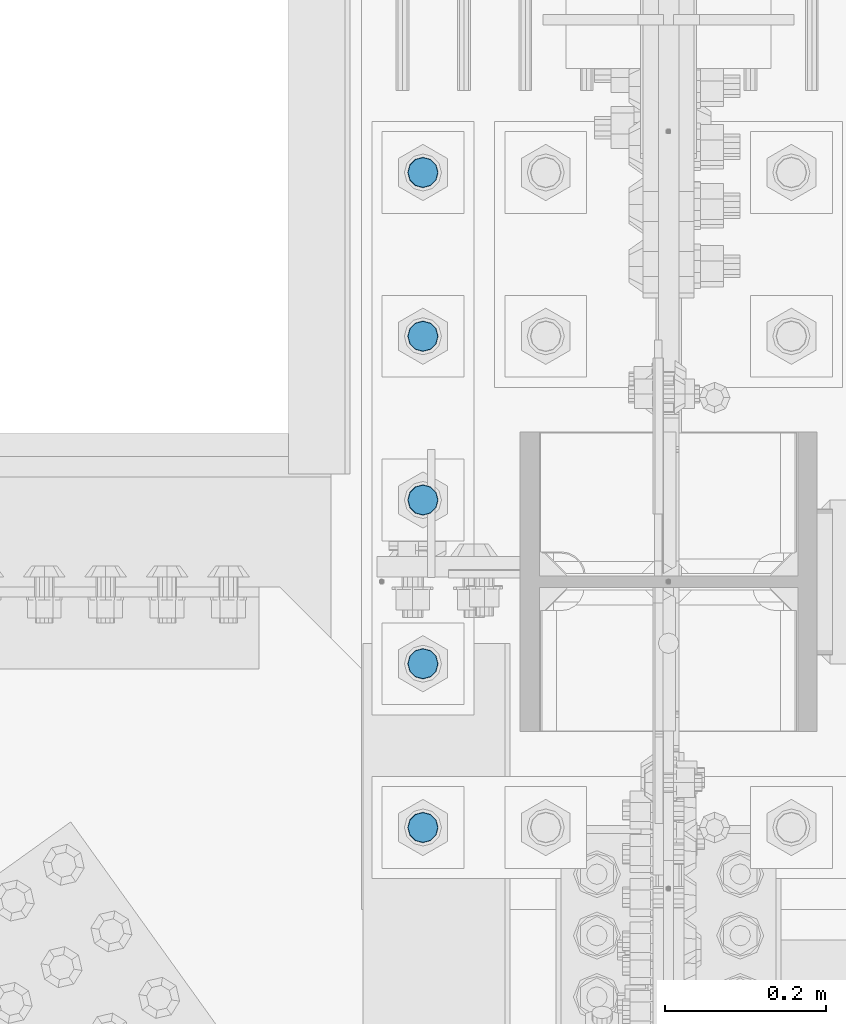
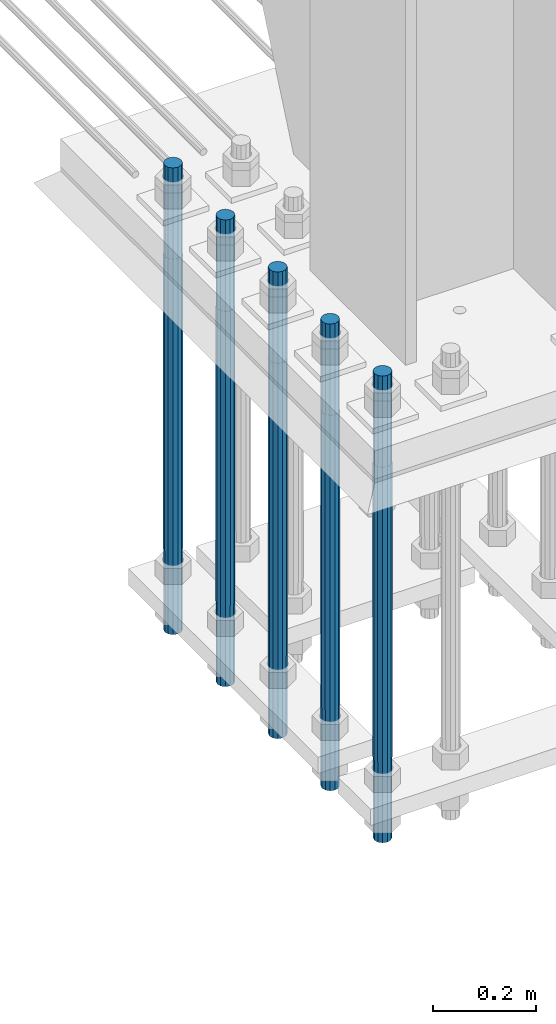
# One storey, part 1422 of 3843: 5 columns, 1 element without a shape of its own.
"""IFC2X3 building model written with IfcOpenShell, lengths in millimetres."""

from ifc_helpers import new_model, si_unit, frame, origin_with_axes, place, context, subcontext, project, spatial, faceted_brep, material, type_object, element, aggregate, save


model = new_model("IFC2X3")

# Units and contexts
model_context = context("Model", 3, precision=1e-05, world=origin_with_axes())
body_context = subcontext(model_context, "Body", "Model", "MODEL_VIEW")
ifc_project = project(units=[si_unit("LENGTHUNIT", "METRE", prefix="MILLI"), si_unit("AREAUNIT", "SQUARE_METRE"), si_unit("VOLUMEUNIT", "CUBIC_METRE"), si_unit("MASSUNIT", "GRAM", prefix="KILO"), si_unit("TIMEUNIT", "SECOND"), si_unit("PLANEANGLEUNIT", "RADIAN"), si_unit("SOLIDANGLEUNIT", "STERADIAN"), si_unit("THERMODYNAMICTEMPERATUREUNIT", "DEGREE_CELSIUS"), si_unit("LUMINOUSINTENSITYUNIT", "LUMEN")], contexts=[model_context])

# Site, building, storey
site_placement = place(None, origin_with_axes())
site = spatial("IfcSite", under=ifc_project, at=site_placement, CompositionType="ELEMENT")
building_placement = place(site_placement, origin_with_axes())
building = spatial("IfcBuilding", under=site, at=building_placement, Name="Undefined", CompositionType="ELEMENT")
storey_placement = place(building_placement, origin_with_axes())
storey = spatial("IfcBuildingStorey", under=building, at=storey_placement, Name="Undefined", CompositionType="ELEMENT", Elevation=0.0)

# Assembly, columns
assembly_placement = place(storey_placement, origin_with_axes())
assembly = element("IfcElementAssembly", 1, at=assembly_placement, inside=storey, Name="TEMPLATE", AssemblyPlace="NOTDEFINED", PredefinedType="RIGID_FRAME")
ifc_material = material(Name="Undefined/F1554-GR.55")
column_type = type_object("IfcColumnType", PredefinedType="NOTDEFINED")
column_1_placement = place(assembly_placement, frame((85344.0, 91909.9, 29565.6), z_axis=(1.0, 0.0, 0.0), x_axis=(0.0, 0.0, -1.0)))
column_1 = element("IfcColumn", 2, at=column_1_placement, type_object=column_type, material=ifc_material, Name="ANCHOR_ROD", context=body_context, shape_type="Brep", body=[
    faceted_brep([(-215.899999999998, -16.0214699700118, 9.25), (-215.899999999998, -9.25, 16.0214699700155), (-215.899999999998, 0.0, 18.5), (-215.899999999998, 9.25, 16.0214699700155), (-215.899999999998, 16.0214699700118, 9.25), (-215.899999999998, 18.5, 0.0), (-215.899999999998, 16.0214699700118, -9.25), (-215.899999999998, 9.25, -16.0214699700155), (-215.899999999998, 0.0, -18.5), (-215.899999999998, -9.25, -16.0214699700155), (-215.899999999998, -16.0214699700118, -9.25), (-215.899999999998, -18.5, 0.0), (0.0, 18.5, 0.0), (0.0, 16.0214699700118, -9.25), (0.0, 9.25, -16.0214699700155), (0.0, 0.0, -18.5), (0.0, -9.25, -16.0214699700155), (0.0, -16.0214699700118, -9.25), (0.0, -18.5, 0.0), (0.0, -16.0214699700118, 9.25), (0.0, -9.25, 16.0214699700155), (0.0, 0.0, 18.5), (0.0, 9.25, 16.0214699700155), (0.0, 16.0214699700118, 9.25), (0.0, -16.4977839420972, 9.52500000000146), (0.0, -9.52500000000146, 16.4977839420972), (0.0, 0.0, 19.0499989999989), (0.0, 9.52500000000146, 16.4977839420972), (0.0, 16.4977839420972, 9.52500000000146), (0.0, 19.0500000000029, 0.0), (0.0, 16.4977839420972, -9.52500000000146), (0.0, 9.52500000000146, -16.4977839420972), (0.0, 0.0, -19.0499989999989), (0.0, -9.52500000000146, -16.4977839420972), (0.0, -16.4977839420972, -9.52500000000146), (0.0, -19.0500000000029, 0.0), (698.5, -19.0499999999993, 0.0), (698.5, -16.4977839420935, 9.52499999999418), (698.5, -9.52500000000146, 16.4977839420899), (698.5, 0.0, 19.0500000000029), (698.5, 9.52500000000146, 16.4977839420899), (698.5, 16.4977839420935, 9.52499999999418), (698.5, 19.0499999999993, 0.0), (698.5, 16.4977839420935, -9.52499999999418), (698.5, 9.52500000000146, -16.4977839420899), (698.5, 0.0, -19.0500000000029), (698.5, -9.52500000000146, -16.4977839420899), (698.5, -16.4977839420935, -9.52499999999418), (698.5, -9.25, 16.0214699700155), (698.5, 0.0, 18.5), (698.5, 9.25, 16.0214699700155), (698.5, 16.0214699700118, 9.25), (698.5, 18.5, 0.0), (698.5, 16.0214699700118, -9.25), (698.5, 9.25, -16.0214699700155), (698.5, 0.0, -18.5), (698.5, -9.25, -16.0214699700155), (698.5, -16.0214699700118, -9.25), (698.5, -18.5, 0.0), (698.5, -16.0214699700118, 9.25), (889.0, -9.25, -16.0214699700155), (889.0, 0.0, -18.5), (889.0, 9.25, -16.0214699700155), (889.0, 16.0214699700118, -9.25), (889.0, 18.5, 0.0), (889.0, 16.0214699700118, 9.25), (889.0, 9.25, 16.0214699700155), (889.0, 0.0, 18.5), (889.0, -9.25, 16.0214699700155), (889.0, -16.0214699700118, 9.25), (889.0, -18.5, 0.0), (889.0, -16.0214699700118, -9.25)], [[[0, 1, 2, 3, 4, 5, 6, 7, 8, 9, 10, 11]], [[6, 5, 12, 13]], [[7, 6, 13, 14]], [[8, 7, 14, 15]], [[9, 8, 15, 16]], [[10, 9, 16, 17]], [[11, 10, 17, 18]], [[0, 11, 18, 19]], [[1, 0, 19, 20]], [[2, 1, 20, 21]], [[3, 2, 21, 22]], [[4, 3, 22, 23]], [[5, 4, 23, 12]], [[24, 25, 26, 27, 28, 29, 30, 31, 32, 33, 34, 35], [22, 21, 20, 19, 18, 17, 16, 15, 14, 13, 12, 23]], [[24, 35, 36, 37]], [[25, 24, 37, 38]], [[26, 25, 38, 39]], [[27, 26, 39, 40]], [[28, 27, 40, 41]], [[29, 28, 41, 42]], [[30, 29, 42, 43]], [[31, 30, 43, 44]], [[32, 31, 44, 45]], [[33, 32, 45, 46]], [[34, 33, 46, 47]], [[35, 34, 47, 36]], [[46, 45, 44, 43, 42, 41, 40, 39, 38, 37, 36, 47], [48, 49, 50, 51, 52, 53, 54, 55, 56, 57, 58, 59]], [[60, 61, 62, 63, 64, 65, 66, 67, 68, 69, 70, 71]], [[68, 67, 49, 48]], [[69, 68, 48, 59]], [[70, 69, 59, 58]], [[71, 70, 58, 57]], [[60, 71, 57, 56]], [[61, 60, 56, 55]], [[62, 61, 55, 54]], [[63, 62, 54, 53]], [[64, 63, 53, 52]], [[65, 64, 52, 51]], [[66, 65, 51, 50]], [[67, 66, 50, 49]]]),
])
column_2_placement = place(assembly_placement, frame((85344.0, 92113.1, 29565.6), z_axis=(1.0, 0.0, 0.0), x_axis=(0.0, 0.0, -1.0)))
column_2 = element("IfcColumn", 3, at=column_2_placement, type_object=column_type, material=ifc_material, Name="ANCHOR_ROD", context=body_context, shape_type="Brep", body=[
    faceted_brep([(-215.899999999998, -16.0214699700118, 9.25), (-215.899999999998, -9.25, 16.0214699700155), (-215.899999999998, 0.0, 18.5), (-215.899999999998, 9.25, 16.0214699700155), (-215.899999999998, 16.0214699700118, 9.25), (-215.899999999998, 18.5, 0.0), (-215.899999999998, 16.0214699700118, -9.25), (-215.899999999998, 9.25, -16.0214699700155), (-215.899999999998, 0.0, -18.5), (-215.899999999998, -9.25, -16.0214699700155), (-215.899999999998, -16.0214699700118, -9.25), (-215.899999999998, -18.5, 0.0), (0.0, 18.5, 0.0), (0.0, 16.0214699700118, -9.25), (0.0, 9.25, -16.0214699700155), (0.0, 0.0, -18.5), (0.0, -9.25, -16.0214699700155), (0.0, -16.0214699700118, -9.25), (0.0, -18.5, 0.0), (0.0, -16.0214699700118, 9.25), (0.0, -9.25, 16.0214699700155), (0.0, 0.0, 18.5), (0.0, 9.25, 16.0214699700155), (0.0, 16.0214699700118, 9.25), (0.0, -16.4977839420972, 9.52500000000146), (0.0, -9.52500000000146, 16.4977839420972), (0.0, 0.0, 19.0499989999989), (0.0, 9.52500000000146, 16.4977839420972), (0.0, 16.4977839420972, 9.52500000000146), (0.0, 19.0500000000029, 0.0), (0.0, 16.4977839420972, -9.52500000000146), (0.0, 9.52500000000146, -16.4977839420972), (0.0, 0.0, -19.0499989999989), (0.0, -9.52500000000146, -16.4977839420972), (0.0, -16.4977839420972, -9.52500000000146), (0.0, -19.0500000000029, 0.0), (698.5, -19.0499999999993, 0.0), (698.5, -16.4977839420935, 9.52499999999418), (698.5, -9.52500000000146, 16.4977839420899), (698.5, 0.0, 19.0500000000029), (698.5, 9.52500000000146, 16.4977839420899), (698.5, 16.4977839420935, 9.52499999999418), (698.5, 19.0499999999993, 0.0), (698.5, 16.4977839420935, -9.52499999999418), (698.5, 9.52500000000146, -16.4977839420899), (698.5, 0.0, -19.0500000000029), (698.5, -9.52500000000146, -16.4977839420899), (698.5, -16.4977839420935, -9.52499999999418), (698.5, -9.25, 16.0214699700155), (698.5, 0.0, 18.5), (698.5, 9.25, 16.0214699700155), (698.5, 16.0214699700118, 9.25), (698.5, 18.5, 0.0), (698.5, 16.0214699700118, -9.25), (698.5, 9.25, -16.0214699700155), (698.5, 0.0, -18.5), (698.5, -9.25, -16.0214699700155), (698.5, -16.0214699700118, -9.25), (698.5, -18.5, 0.0), (698.5, -16.0214699700118, 9.25), (889.0, -9.25, -16.0214699700155), (889.0, 0.0, -18.5), (889.0, 9.25, -16.0214699700155), (889.0, 16.0214699700118, -9.25), (889.0, 18.5, 0.0), (889.0, 16.0214699700118, 9.25), (889.0, 9.25, 16.0214699700155), (889.0, 0.0, 18.5), (889.0, -9.25, 16.0214699700155), (889.0, -16.0214699700118, 9.25), (889.0, -18.5, 0.0), (889.0, -16.0214699700118, -9.25)], [[[0, 1, 2, 3, 4, 5, 6, 7, 8, 9, 10, 11]], [[6, 5, 12, 13]], [[7, 6, 13, 14]], [[8, 7, 14, 15]], [[9, 8, 15, 16]], [[10, 9, 16, 17]], [[11, 10, 17, 18]], [[0, 11, 18, 19]], [[1, 0, 19, 20]], [[2, 1, 20, 21]], [[3, 2, 21, 22]], [[4, 3, 22, 23]], [[5, 4, 23, 12]], [[24, 25, 26, 27, 28, 29, 30, 31, 32, 33, 34, 35], [22, 21, 20, 19, 18, 17, 16, 15, 14, 13, 12, 23]], [[24, 35, 36, 37]], [[25, 24, 37, 38]], [[26, 25, 38, 39]], [[27, 26, 39, 40]], [[28, 27, 40, 41]], [[29, 28, 41, 42]], [[30, 29, 42, 43]], [[31, 30, 43, 44]], [[32, 31, 44, 45]], [[33, 32, 45, 46]], [[34, 33, 46, 47]], [[35, 34, 47, 36]], [[46, 45, 44, 43, 42, 41, 40, 39, 38, 37, 36, 47], [48, 49, 50, 51, 52, 53, 54, 55, 56, 57, 58, 59]], [[60, 61, 62, 63, 64, 65, 66, 67, 68, 69, 70, 71]], [[68, 67, 49, 48]], [[69, 68, 48, 59]], [[70, 69, 59, 58]], [[71, 70, 58, 57]], [[60, 71, 57, 56]], [[61, 60, 56, 55]], [[62, 61, 55, 54]], [[63, 62, 54, 53]], [[64, 63, 53, 52]], [[65, 64, 52, 51]], [[66, 65, 51, 50]], [[67, 66, 50, 49]]]),
])
column_3_placement = place(assembly_placement, frame((85344.0, 92316.3, 29565.6), z_axis=(1.0, 0.0, 0.0), x_axis=(0.0, 0.0, -1.0)))
column_3 = element("IfcColumn", 4, at=column_3_placement, type_object=column_type, material=ifc_material, Name="ANCHOR_ROD", context=body_context, shape_type="Brep", body=[
    faceted_brep([(-215.899999999998, -16.0214699700118, 9.25), (-215.899999999998, -9.25, 16.0214699700155), (-215.899999999998, 0.0, 18.5), (-215.899999999998, 9.25, 16.0214699700155), (-215.899999999998, 16.0214699700118, 9.25), (-215.899999999998, 18.5, 0.0), (-215.899999999998, 16.0214699700118, -9.25), (-215.899999999998, 9.25, -16.0214699700155), (-215.899999999998, 0.0, -18.5), (-215.899999999998, -9.25, -16.0214699700155), (-215.899999999998, -16.0214699700118, -9.25), (-215.899999999998, -18.5, 0.0), (0.0, 18.5, 0.0), (0.0, 16.0214699700118, -9.25), (0.0, 9.25, -16.0214699700155), (0.0, 0.0, -18.5), (0.0, -9.25, -16.0214699700155), (0.0, -16.0214699700118, -9.25), (0.0, -18.5, 0.0), (0.0, -16.0214699700118, 9.25), (0.0, -9.25, 16.0214699700155), (0.0, 0.0, 18.5), (0.0, 9.25, 16.0214699700155), (0.0, 16.0214699700118, 9.25), (0.0, -16.4977839420972, 9.52500000000146), (0.0, -9.52500000000146, 16.4977839420972), (0.0, 0.0, 19.0499989999989), (0.0, 9.52500000000146, 16.4977839420972), (0.0, 16.4977839420972, 9.52500000000146), (0.0, 19.0500000000029, 0.0), (0.0, 16.4977839420972, -9.52500000000146), (0.0, 9.52500000000146, -16.4977839420972), (0.0, 0.0, -19.0499989999989), (0.0, -9.52500000000146, -16.4977839420972), (0.0, -16.4977839420972, -9.52500000000146), (0.0, -19.0500000000029, 0.0), (698.5, -19.0499999999993, 0.0), (698.5, -16.4977839420935, 9.52499999999418), (698.5, -9.52500000000146, 16.4977839420899), (698.5, 0.0, 19.0500000000029), (698.5, 9.52500000000146, 16.4977839420899), (698.5, 16.4977839420935, 9.52499999999418), (698.5, 19.0499999999993, 0.0), (698.5, 16.4977839420935, -9.52499999999418), (698.5, 9.52500000000146, -16.4977839420899), (698.5, 0.0, -19.0500000000029), (698.5, -9.52500000000146, -16.4977839420899), (698.5, -16.4977839420935, -9.52499999999418), (698.5, -9.25, 16.0214699700155), (698.5, 0.0, 18.5), (698.5, 9.25, 16.0214699700155), (698.5, 16.0214699700118, 9.25), (698.5, 18.5, 0.0), (698.5, 16.0214699700118, -9.25), (698.5, 9.25, -16.0214699700155), (698.5, 0.0, -18.5), (698.5, -9.25, -16.0214699700155), (698.5, -16.0214699700118, -9.25), (698.5, -18.5, 0.0), (698.5, -16.0214699700118, 9.25), (889.0, -9.25, -16.0214699700155), (889.0, 0.0, -18.5), (889.0, 9.25, -16.0214699700155), (889.0, 16.0214699700118, -9.25), (889.0, 18.5, 0.0), (889.0, 16.0214699700118, 9.25), (889.0, 9.25, 16.0214699700155), (889.0, 0.0, 18.5), (889.0, -9.25, 16.0214699700155), (889.0, -16.0214699700118, 9.25), (889.0, -18.5, 0.0), (889.0, -16.0214699700118, -9.25)], [[[0, 1, 2, 3, 4, 5, 6, 7, 8, 9, 10, 11]], [[6, 5, 12, 13]], [[7, 6, 13, 14]], [[8, 7, 14, 15]], [[9, 8, 15, 16]], [[10, 9, 16, 17]], [[11, 10, 17, 18]], [[0, 11, 18, 19]], [[1, 0, 19, 20]], [[2, 1, 20, 21]], [[3, 2, 21, 22]], [[4, 3, 22, 23]], [[5, 4, 23, 12]], [[24, 25, 26, 27, 28, 29, 30, 31, 32, 33, 34, 35], [22, 21, 20, 19, 18, 17, 16, 15, 14, 13, 12, 23]], [[24, 35, 36, 37]], [[25, 24, 37, 38]], [[26, 25, 38, 39]], [[27, 26, 39, 40]], [[28, 27, 40, 41]], [[29, 28, 41, 42]], [[30, 29, 42, 43]], [[31, 30, 43, 44]], [[32, 31, 44, 45]], [[33, 32, 45, 46]], [[34, 33, 46, 47]], [[35, 34, 47, 36]], [[46, 45, 44, 43, 42, 41, 40, 39, 38, 37, 36, 47], [48, 49, 50, 51, 52, 53, 54, 55, 56, 57, 58, 59]], [[60, 61, 62, 63, 64, 65, 66, 67, 68, 69, 70, 71]], [[68, 67, 49, 48]], [[69, 68, 48, 59]], [[70, 69, 59, 58]], [[71, 70, 58, 57]], [[60, 71, 57, 56]], [[61, 60, 56, 55]], [[62, 61, 55, 54]], [[63, 62, 54, 53]], [[64, 63, 53, 52]], [[65, 64, 52, 51]], [[66, 65, 51, 50]], [[67, 66, 50, 49]]]),
])
column_4_placement = place(assembly_placement, frame((85344.0, 92519.5, 29565.6), z_axis=(-1.0, 0.0, 0.0), x_axis=(0.0, 0.0, -1.0)))
column_4 = element("IfcColumn", 5, at=column_4_placement, type_object=column_type, material=ifc_material, Name="ANCHOR_ROD", context=body_context, shape_type="Brep", body=[
    faceted_brep([(-215.899999999998, -16.0214699700118, 9.25), (-215.899999999998, -9.25, 16.0214699700155), (-215.899999999998, 0.0, 18.5), (-215.899999999998, 9.25, 16.0214699700155), (-215.899999999998, 16.0214699700118, 9.25), (-215.899999999998, 18.5, 0.0), (-215.899999999998, 16.0214699700118, -9.25), (-215.899999999998, 9.25, -16.0214699700155), (-215.899999999998, 0.0, -18.5), (-215.899999999998, -9.25, -16.0214699700155), (-215.899999999998, -16.0214699700118, -9.25), (-215.899999999998, -18.5, 0.0), (0.0, 18.5, 0.0), (0.0, 16.0214699700118, -9.25), (0.0, 9.25, -16.0214699700155), (0.0, 0.0, -18.5), (0.0, -9.25, -16.0214699700155), (0.0, -16.0214699700118, -9.25), (0.0, -18.5, 0.0), (0.0, -16.0214699700118, 9.25), (0.0, -9.25, 16.0214699700155), (0.0, 0.0, 18.5), (0.0, 9.25, 16.0214699700155), (0.0, 16.0214699700118, 9.25), (0.0, -16.4977839420972, 9.52500000000146), (0.0, -9.52500000000146, 16.4977839420972), (0.0, 0.0, 19.0499989999989), (0.0, 9.52500000000146, 16.4977839420972), (0.0, 16.4977839420972, 9.52500000000146), (0.0, 19.0500000000029, 0.0), (0.0, 16.4977839420972, -9.52500000000146), (0.0, 9.52500000000146, -16.4977839420972), (0.0, 0.0, -19.0499989999989), (0.0, -9.52500000000146, -16.4977839420972), (0.0, -16.4977839420972, -9.52500000000146), (0.0, -19.0500000000029, 0.0), (698.5, -19.0499999999993, 0.0), (698.5, -16.4977839420935, 9.52499999999418), (698.5, -9.52500000000146, 16.4977839420899), (698.5, 0.0, 19.0500000000029), (698.5, 9.52500000000146, 16.4977839420899), (698.5, 16.4977839420935, 9.52499999999418), (698.5, 19.0499999999993, 0.0), (698.5, 16.4977839420935, -9.52499999999418), (698.5, 9.52500000000146, -16.4977839420899), (698.5, 0.0, -19.0500000000029), (698.5, -9.52500000000146, -16.4977839420899), (698.5, -16.4977839420935, -9.52499999999418), (698.5, -9.25, 16.0214699700155), (698.5, 0.0, 18.5), (698.5, 9.25, 16.0214699700155), (698.5, 16.0214699700118, 9.25), (698.5, 18.5, 0.0), (698.5, 16.0214699700118, -9.25), (698.5, 9.25, -16.0214699700155), (698.5, 0.0, -18.5), (698.5, -9.25, -16.0214699700155), (698.5, -16.0214699700118, -9.25), (698.5, -18.5, 0.0), (698.5, -16.0214699700118, 9.25), (889.0, -9.25, -16.0214699700155), (889.0, 0.0, -18.5), (889.0, 9.25, -16.0214699700155), (889.0, 16.0214699700118, -9.25), (889.0, 18.5, 0.0), (889.0, 16.0214699700118, 9.25), (889.0, 9.25, 16.0214699700155), (889.0, 0.0, 18.5), (889.0, -9.25, 16.0214699700155), (889.0, -16.0214699700118, 9.25), (889.0, -18.5, 0.0), (889.0, -16.0214699700118, -9.25)], [[[0, 1, 2, 3, 4, 5, 6, 7, 8, 9, 10, 11]], [[6, 5, 12, 13]], [[7, 6, 13, 14]], [[8, 7, 14, 15]], [[9, 8, 15, 16]], [[10, 9, 16, 17]], [[11, 10, 17, 18]], [[0, 11, 18, 19]], [[1, 0, 19, 20]], [[2, 1, 20, 21]], [[3, 2, 21, 22]], [[4, 3, 22, 23]], [[5, 4, 23, 12]], [[24, 25, 26, 27, 28, 29, 30, 31, 32, 33, 34, 35], [22, 21, 20, 19, 18, 17, 16, 15, 14, 13, 12, 23]], [[24, 35, 36, 37]], [[25, 24, 37, 38]], [[26, 25, 38, 39]], [[27, 26, 39, 40]], [[28, 27, 40, 41]], [[29, 28, 41, 42]], [[30, 29, 42, 43]], [[31, 30, 43, 44]], [[32, 31, 44, 45]], [[33, 32, 45, 46]], [[34, 33, 46, 47]], [[35, 34, 47, 36]], [[46, 45, 44, 43, 42, 41, 40, 39, 38, 37, 36, 47], [48, 49, 50, 51, 52, 53, 54, 55, 56, 57, 58, 59]], [[60, 61, 62, 63, 64, 65, 66, 67, 68, 69, 70, 71]], [[68, 67, 49, 48]], [[69, 68, 48, 59]], [[70, 69, 59, 58]], [[71, 70, 58, 57]], [[60, 71, 57, 56]], [[61, 60, 56, 55]], [[62, 61, 55, 54]], [[63, 62, 54, 53]], [[64, 63, 53, 52]], [[65, 64, 52, 51]], [[66, 65, 51, 50]], [[67, 66, 50, 49]]]),
])
column_5_placement = place(assembly_placement, frame((85344.0, 92722.7, 29565.6), z_axis=(-1.0, 0.0, 0.0), x_axis=(0.0, 0.0, -1.0)))
column_5 = element("IfcColumn", 6, at=column_5_placement, type_object=column_type, material=ifc_material, Name="ANCHOR_ROD", context=body_context, shape_type="Brep", body=[
    faceted_brep([(-215.899999999998, -16.0214699700118, 9.25), (-215.899999999998, -9.25, 16.0214699700155), (-215.899999999998, 0.0, 18.5), (-215.899999999998, 9.25, 16.0214699700155), (-215.899999999998, 16.0214699700118, 9.25), (-215.899999999998, 18.5, 0.0), (-215.899999999998, 16.0214699700118, -9.25), (-215.899999999998, 9.25, -16.0214699700155), (-215.899999999998, 0.0, -18.5), (-215.899999999998, -9.25, -16.0214699700155), (-215.899999999998, -16.0214699700118, -9.25), (-215.899999999998, -18.5, 0.0), (0.0, 18.5, 0.0), (0.0, 16.0214699700118, -9.25), (0.0, 9.25, -16.0214699700155), (0.0, 0.0, -18.5), (0.0, -9.25, -16.0214699700155), (0.0, -16.0214699700118, -9.25), (0.0, -18.5, 0.0), (0.0, -16.0214699700118, 9.25), (0.0, -9.25, 16.0214699700155), (0.0, 0.0, 18.5), (0.0, 9.25, 16.0214699700155), (0.0, 16.0214699700118, 9.25), (0.0, -16.4977839420972, 9.52500000000146), (0.0, -9.52500000000146, 16.4977839420972), (0.0, 0.0, 19.0499989999989), (0.0, 9.52500000000146, 16.4977839420972), (0.0, 16.4977839420972, 9.52500000000146), (0.0, 19.0500000000029, 0.0), (0.0, 16.4977839420972, -9.52500000000146), (0.0, 9.52500000000146, -16.4977839420972), (0.0, 0.0, -19.0499989999989), (0.0, -9.52500000000146, -16.4977839420972), (0.0, -16.4977839420972, -9.52500000000146), (0.0, -19.0500000000029, 0.0), (698.5, -19.0499999999993, 0.0), (698.5, -16.4977839420935, 9.52499999999418), (698.5, -9.52500000000146, 16.4977839420899), (698.5, 0.0, 19.0500000000029), (698.5, 9.52500000000146, 16.4977839420899), (698.5, 16.4977839420935, 9.52499999999418), (698.5, 19.0499999999993, 0.0), (698.5, 16.4977839420935, -9.52499999999418), (698.5, 9.52500000000146, -16.4977839420899), (698.5, 0.0, -19.0500000000029), (698.5, -9.52500000000146, -16.4977839420899), (698.5, -16.4977839420935, -9.52499999999418), (698.5, -9.25, 16.0214699700155), (698.5, 0.0, 18.5), (698.5, 9.25, 16.0214699700155), (698.5, 16.0214699700118, 9.25), (698.5, 18.5, 0.0), (698.5, 16.0214699700118, -9.25), (698.5, 9.25, -16.0214699700155), (698.5, 0.0, -18.5), (698.5, -9.25, -16.0214699700155), (698.5, -16.0214699700118, -9.25), (698.5, -18.5, 0.0), (698.5, -16.0214699700118, 9.25), (889.0, -9.25, -16.0214699700155), (889.0, 0.0, -18.5), (889.0, 9.25, -16.0214699700155), (889.0, 16.0214699700118, -9.25), (889.0, 18.5, 0.0), (889.0, 16.0214699700118, 9.25), (889.0, 9.25, 16.0214699700155), (889.0, 0.0, 18.5), (889.0, -9.25, 16.0214699700155), (889.0, -16.0214699700118, 9.25), (889.0, -18.5, 0.0), (889.0, -16.0214699700118, -9.25)], [[[0, 1, 2, 3, 4, 5, 6, 7, 8, 9, 10, 11]], [[6, 5, 12, 13]], [[7, 6, 13, 14]], [[8, 7, 14, 15]], [[9, 8, 15, 16]], [[10, 9, 16, 17]], [[11, 10, 17, 18]], [[0, 11, 18, 19]], [[1, 0, 19, 20]], [[2, 1, 20, 21]], [[3, 2, 21, 22]], [[4, 3, 22, 23]], [[5, 4, 23, 12]], [[24, 25, 26, 27, 28, 29, 30, 31, 32, 33, 34, 35], [22, 21, 20, 19, 18, 17, 16, 15, 14, 13, 12, 23]], [[24, 35, 36, 37]], [[25, 24, 37, 38]], [[26, 25, 38, 39]], [[27, 26, 39, 40]], [[28, 27, 40, 41]], [[29, 28, 41, 42]], [[30, 29, 42, 43]], [[31, 30, 43, 44]], [[32, 31, 44, 45]], [[33, 32, 45, 46]], [[34, 33, 46, 47]], [[35, 34, 47, 36]], [[46, 45, 44, 43, 42, 41, 40, 39, 38, 37, 36, 47], [48, 49, 50, 51, 52, 53, 54, 55, 56, 57, 58, 59]], [[60, 61, 62, 63, 64, 65, 66, 67, 68, 69, 70, 71]], [[68, 67, 49, 48]], [[69, 68, 48, 59]], [[70, 69, 59, 58]], [[71, 70, 58, 57]], [[60, 71, 57, 56]], [[61, 60, 56, 55]], [[62, 61, 55, 54]], [[63, 62, 54, 53]], [[64, 63, 53, 52]], [[65, 64, 52, 51]], [[66, 65, 51, 50]], [[67, 66, 50, 49]]]),
])
aggregate(assembly, [column_1, column_2, column_3, column_4, column_5])

save(model, "model.ifc")
